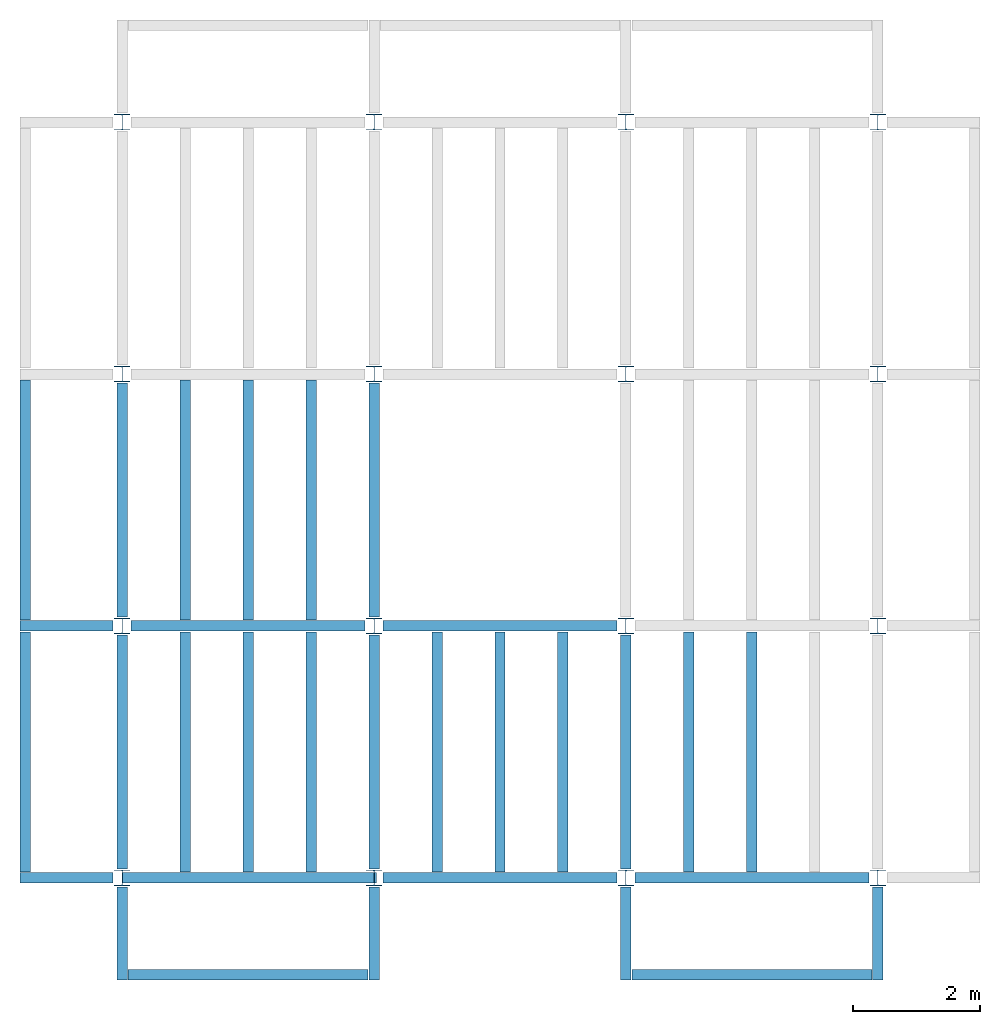
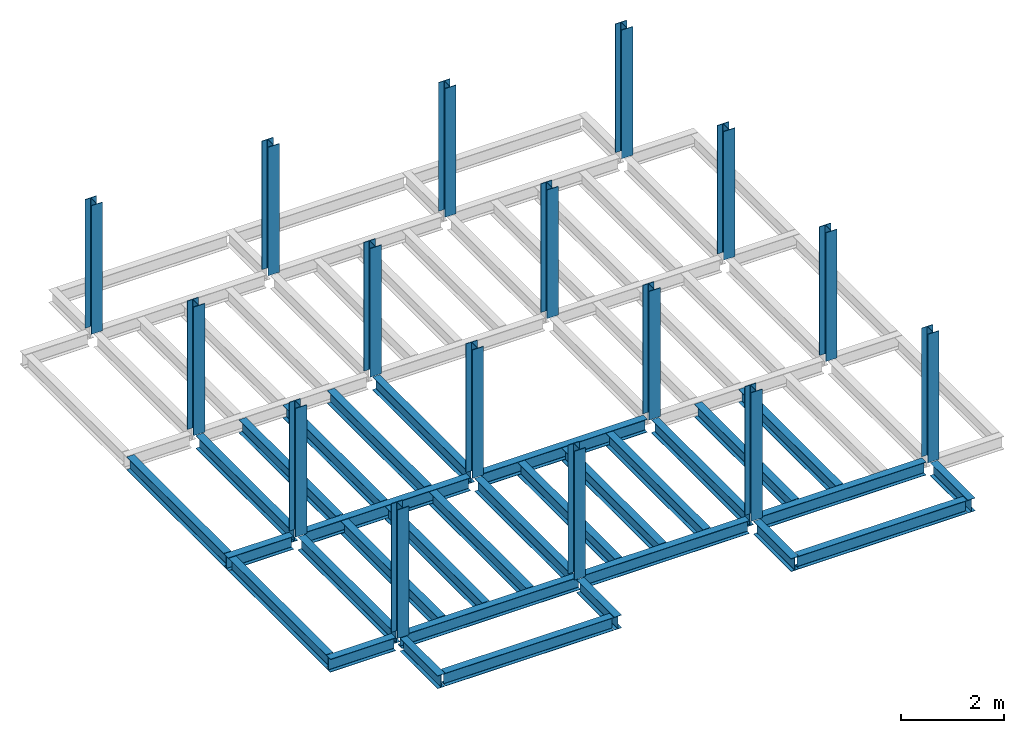
# One storey, part 1 of 3: 31 beams, 16 columns, 4 elements without a shape of their own.
"""IFC4 building model written with IfcOpenShell, lengths in feet."""

from ifc_helpers import new_model, entity, si_unit, converted_unit, derived_unit, direction, frame, origin, origin_2d, place, context, subcontext, project, spatial, line, arc, indexed_curve, i_section, outline, extrude, source, transform, mapped, material, type_object, type_shapes, element, aggregate, save


model = new_model("IFC4")

# Units and contexts
model_context = context("Model", 3, precision=0.0001, world=origin(), true_north=direction((6.123233995736766e-17, 1.0)))
plan_context = context("Plan", 3, precision=0.0001, world=origin(), true_north=direction((6.123233995736766e-17, 1.0)))
body_context = subcontext(model_context, "Body", "Model", "MODEL_VIEW")
ifc_project = project(units=[converted_unit("LENGTHUNIT", "FOOT", entity("IfcLengthMeasure", 0.3048), si_unit("LENGTHUNIT", "METRE"), dimensions=[1, 0, 0, 0, 0, 0, 0]), converted_unit("AREAUNIT", "SQUARE FOOT", entity("IfcAreaMeasure", 0.09290304), si_unit("AREAUNIT", "SQUARE_METRE"), dimensions=[2, 0, 0, 0, 0, 0, 0]), converted_unit("PLANEANGLEUNIT", "DEGREE", entity("IfcPlaneAngleMeasure", 0.017453292519943278), si_unit("PLANEANGLEUNIT", "RADIAN"), dimensions=[0, 0, 0, 0, 0, 0, 0]), converted_unit("VOLUMEUNIT", "CUBIC FOOT", entity("IfcVolumeMeasure", 0.028316846592000004), si_unit("VOLUMEUNIT", "CUBIC_METRE"), dimensions=[3, 0, 0, 0, 0, 0, 0]), si_unit("PRESSUREUNIT", "PASCAL"), derived_unit("MASSDENSITYUNIT", [(si_unit("MASSUNIT", "GRAM", prefix="KILO"), 1), (si_unit("LENGTHUNIT", "METRE"), -3)]), derived_unit("VAPORPERMEABILITYUNIT", [(si_unit("LENGTHUNIT", "METRE"), -1), (si_unit("TIMEUNIT", "SECOND"), 1)]), derived_unit("USERDEFINED", [(si_unit("MASSUNIT", "GRAM", prefix="KILO"), 1), (si_unit("LENGTHUNIT", "METRE"), 3), (si_unit("TIMEUNIT", "SECOND"), -3), (si_unit("ELECTRICCURRENTUNIT", "AMPERE"), -2)]), derived_unit("MODULUSOFELASTICITYUNIT", [(si_unit("MASSUNIT", "GRAM", prefix="KILO"), 1), (si_unit("LENGTHUNIT", "METRE"), -1), (si_unit("TIMEUNIT", "SECOND"), -2)]), derived_unit("THERMALEXPANSIONCOEFFICIENTUNIT", [(si_unit("THERMODYNAMICTEMPERATUREUNIT", "KELVIN"), -1)]), derived_unit("SPECIFICHEATCAPACITYUNIT", [(si_unit("TIMEUNIT", "SECOND"), -2), (si_unit("THERMODYNAMICTEMPERATUREUNIT", "KELVIN"), -1), (si_unit("LENGTHUNIT", "METRE"), 2)]), derived_unit("THERMALCONDUCTANCEUNIT", [(si_unit("MASSUNIT", "GRAM", prefix="KILO"), 1), (si_unit("TIMEUNIT", "SECOND"), -3), (si_unit("THERMODYNAMICTEMPERATUREUNIT", "KELVIN"), -1), (si_unit("LENGTHUNIT", "METRE"), 1)])], contexts=[model_context, plan_context])

# Site, building, storey
site_placement = place(None, origin())
site = spatial("IfcSite", under=ifc_project, at=site_placement, CompositionType="ELEMENT")
building_placement = place(site_placement, origin())
building = spatial("IfcBuilding", under=site, at=building_placement, CompositionType="ELEMENT")
storey_placement = place(building_placement, frame((0.0, 0.0, 99.875)))
storey = spatial("IfcBuildingStorey", under=building, at=storey_placement, Name="STR 11", CompositionType="ELEMENT", Elevation=99.875)

# Columns
ifc_material = material(Name="Steel ASTM A992", Category="Metal")
column_type = type_object("IfcColumnType", Name="W10X49", PredefinedType="COLUMN", material=ifc_material)
shared_shape_1 = source(origin(), body_context, "Body", "SweptSolid", [
    extrude(outline(indexed_curve([(-0.41666666666666663, -0.4166666666666676), (0.41666666666666663, -0.4166666666666676), (0.41666666666666663, -0.3699999999999996), (0.055833333333333846, -0.3699999999999996), (0.02637055078389421, -0.35779611588277277), (0.014166666666666636, -0.32833333333333287), (0.01416666666666665, 0.32833333333333303), (0.026370550783893467, 0.3577961158827727), (0.05583333333333332, 0.3700000000000003), (0.41666666666666663, 0.3700000000000003), (0.41666666666666663, 0.4166666666666656), (-0.41666666666666663, 0.4166666666666656), (-0.41666666666666663, 0.3700000000000003), (-0.05583333333333365, 0.3700000000000003), (-0.02637055078389416, 0.3577961158827734), (-0.014166666666666685, 0.32833333333333387), (-0.014166666666666685, -0.32833333333333264), (-0.026370550783893578, -0.3577961158827721), (-0.055833333333333374, -0.3699999999999996), (-0.41666666666666663, -0.3699999999999996)], segments=[line(1, 2, 3, 4), arc(4, 5, 6), line(6, 7), arc(7, 8, 9), line(9, 10, 11, 12, 13, 14), arc(14, 15, 16), line(16, 17), arc(17, 18, 19), line(19, 20, 1)], self_intersect=False)), frame((0.0, 0.0, 99.875), z_axis=(0.0, 0.0, 1.0), x_axis=(-1.0, 0.0, 0.0)), (0.0, 0.0, 1.0), 10.0),
])
type_shapes(column_type, [shared_shape_1])
for number, where, z_axis, x_axis, name in (
    (1, (0.0, 0.0, -99.875), (0.0, 0.0, 1.0), (-1.0, 0.0, 0.0), "W10X49"),
    (2, (0.0, 13.0, -99.875), (0.0, 0.0, 1.0), (-1.0, 0.0, 0.0), "W10X49"),
    (3, (0.0, 26.0, -99.875), (0.0, 0.0, 1.0), (-1.0, 0.0, 0.0), "W10X49"),
    (4, (0.0, 39.0, -99.875), (0.0, 0.0, 1.0), (-1.0, 0.0, 0.0), "W10X49"),
    (5, (13.0, 0.0, -99.875), (0.0, 0.0, 1.0), (-1.0, 0.0, 0.0), "W10X49"),
    (6, (13.0, 13.0, -99.875), (0.0, 0.0, 1.0), (-1.0, 0.0, 0.0), "W10X49"),
    (7, (13.0, 26.0, -99.875), (0.0, 0.0, 1.0), (-1.0, 0.0, 0.0), "W10X49"),
    (8, (13.0, 39.0, -99.875), (0.0, 0.0, 1.0), (-1.0, 0.0, 0.0), "W10X49"),
    (9, (26.0, 0.0, -99.875), (0.0, 0.0, 1.0), (-1.0, 0.0, 0.0), "W10X49"),
    (10, (26.0, 13.0, -99.875), (0.0, 0.0, 1.0), (-1.0, 0.0, 0.0), "W10X49"),
    (11, (26.0, 26.0, -99.875), (0.0, 0.0, 1.0), (-1.0, 0.0, 0.0), "W10X49"),
    (12, (26.0, 39.0, -99.875), (0.0, 0.0, 1.0), (-1.0, 0.0, 0.0), "W10X49"),
    (13, (39.0, 0.0, -99.875), (0.0, 0.0, 1.0), (-1.0, 0.0, 0.0), "W10X49"),
    (14, (39.0, 13.0, -99.875), (0.0, 0.0, 1.0), (-1.0, 0.0, 0.0), "W10X49"),
    (15, (39.0, 26.0, -99.875), (0.0, 0.0, 1.0), (-1.0, 0.0, 0.0), "W10X49"),
    (16, (39.0, 39.0, -99.875), (0.0, 0.0, 1.0), (-1.0, 0.0, 0.0), "W10X49"),
):
    element("IfcColumn", number, at=place(storey_placement, frame(where, z_axis=z_axis, x_axis=x_axis)), inside=storey, type_object=column_type, material=ifc_material, Name=name, ObjectType="W Shapes-Column:W10X49", PredefinedType="COLUMN", context=body_context, shape_type="MappedRepresentation", body=[
        mapped(shared_shape_1, transform((0.0, 0.0, 0.0), scale=1.0)),
    ])

# Beams
beam_type_1 = type_object("IfcBeamType", Name="W12X26", PredefinedType="JOIST", material=ifc_material)
shared_shape_2 = source(origin(), body_context, "Body", "SweptSolid", [
    extrude(outline(indexed_curve([(-0.27041666666666714, -0.47666666666666574), (-0.27041666666666714, -0.5083333333333351), (0.2704166666666669, -0.5083333333333351), (0.2704166666666669, -0.47666666666666574), (0.03458333333333309, -0.47666666666666574), (0.016905663803669493, -0.46934433619632937), (0.009583333333333202, -0.4516666666666659), (0.0095833333333332, 0.45166666666666705), (0.01690566380366948, 0.4693443361963307), (0.03458333333333325, 0.4766666666666671), (0.2704166666666669, 0.4766666666666671), (0.2704166666666669, 0.5083333333333312), (-0.2704166666666655, 0.5083333333333312), (-0.2704166666666655, 0.4766666666666671), (-0.034583333333333514, 0.47666666666666707), (-0.016905663803669865, 0.46934433619633054), (-0.009583333333333737, 0.45166666666666694), (-0.009583333333333735, -0.4516666666666658), (-0.01690566380367013, -0.4693443361963295), (-0.03458333333333368, -0.47666666666666574)], segments=[line(1, 2, 3, 4, 5), arc(5, 6, 7), line(7, 8), arc(8, 9, 10), line(10, 11, 12, 13, 14, 15), arc(15, 16, 17), line(17, 18), arc(18, 19, 20), line(20, 1)], self_intersect=False)), frame((-6.103346456692914, 0.0, 0.0), z_axis=(-1.0, 0.0, 0.0), x_axis=(0.0, -1.0, 0.0)), (0.0, 0.0, -1.0), 12.083333333333323),
])
type_shapes(beam_type_1, [shared_shape_2])
beam_1_placement = place(storey_placement, frame((6.561679790026266, 13.0, -0.50833333333334)))
element("IfcBeam", 17, at=beam_1_placement, inside=storey, type_object=beam_type_1, material=ifc_material, Name="W12X26", ObjectType="W Shapes:W12X26", PredefinedType="JOIST", context=body_context, shape_type="MappedRepresentation", body=[
    mapped(shared_shape_2, transform((0.0, 0.0, 0.0), scale=1.0)),
])
for number, where, z_axis, x_axis, name in (
    (18, (0.0, 6.561679790026247, -0.50833333333334), (0.0, 0.0, 1.0), (0.0, 1.0, 0.0), "W12X26"),
    (19, (26.0, 6.561679790026162, -0.50833333333334), (0.0, 0.0, 1.0), (0.0, 1.0, 0.0), "W12X26"),
    (20, (13.0, 6.561679790026204, -0.50833333333334), (0.0, 0.0, 1.0), (0.0, 1.0, 0.0), "W12X26"),
):
    element("IfcBeam", number, at=place(storey_placement, frame(where, z_axis=z_axis, x_axis=x_axis)), inside=storey, type_object=beam_type_1, material=ifc_material, Name=name, ObjectType="W Shapes:W12X26", PredefinedType="JOIST", context=body_context, shape_type="MappedRepresentation", body=[
        mapped(shared_shape_2, transform((0.0, 0.0, 0.0), scale=1.0)),
    ])
beam_type_2 = type_object("IfcBeamType", Name="W12X26", PredefinedType="JOIST", material=ifc_material)
shared_shape_3 = source(origin(), body_context, "Body", "SweptSolid", [
    extrude(outline(indexed_curve([(-0.27041666666666714, -0.47666666666666574), (-0.27041666666666714, -0.5083333333333351), (0.2704166666666669, -0.5083333333333351), (0.2704166666666669, -0.47666666666666574), (0.03458333333333309, -0.47666666666666574), (0.016905663803669493, -0.46934433619632937), (0.009583333333333202, -0.4516666666666659), (0.0095833333333332, 0.45166666666666705), (0.01690566380366948, 0.4693443361963307), (0.03458333333333325, 0.4766666666666671), (0.2704166666666669, 0.4766666666666671), (0.2704166666666669, 0.5083333333333312), (-0.2704166666666655, 0.5083333333333312), (-0.2704166666666655, 0.4766666666666671), (-0.034583333333333514, 0.47666666666666707), (-0.016905663803669865, 0.46934433619633054), (-0.009583333333333737, 0.45166666666666694), (-0.009583333333333735, -0.4516666666666658), (-0.01690566380367013, -0.4693443361963295), (-0.03458333333333368, -0.47666666666666574)], segments=[line(1, 2, 3, 4, 5), arc(5, 6, 7), line(7, 8), arc(8, 9, 10), line(10, 11, 12, 13, 14, 15), arc(15, 16, 17), line(17, 18), arc(18, 19, 20), line(20, 1)], self_intersect=False)), frame((-6.226706036745409, 0.0, 0.0), z_axis=(-1.0, 0.0, 0.0), x_axis=(0.0, -1.0, 0.0)), (0.0, 0.0, -1.0), 12.08333333333333),
])
type_shapes(beam_type_2, [shared_shape_3])
for number, where, name in (
    (21, (19.68503937007876, 13.0, -0.50833333333334), "W12X26"),
    (22, (19.68503937007874, 0.0, -0.50833333333334), "W12X26"),
):
    element("IfcBeam", number, at=place(storey_placement, frame(where)), inside=storey, type_object=beam_type_2, material=ifc_material, Name=name, ObjectType="W Shapes:W12X26", PredefinedType="JOIST", context=body_context, shape_type="MappedRepresentation", body=[
        mapped(shared_shape_3, transform((0.0, 0.0, 0.0), scale=1.0)),
    ])
for number, where, z_axis, x_axis, name in (
    (23, (0.0, 19.68503937007874, -0.50833333333334), (0.0, 0.0, 1.0), (0.0, 1.0, 0.0), "W12X26"),
    (24, (13.0, 19.685039370078698, -0.50833333333334), (0.0, 0.0, 1.0), (0.0, 1.0, 0.0), "W12X26"),
):
    element("IfcBeam", number, at=place(storey_placement, frame(where, z_axis=z_axis, x_axis=x_axis)), inside=storey, type_object=beam_type_2, material=ifc_material, Name=name, ObjectType="W Shapes:W12X26", PredefinedType="JOIST", context=body_context, shape_type="MappedRepresentation", body=[
        mapped(shared_shape_3, transform((0.0, 0.0, 0.0), scale=1.0)),
    ])

# Assembly, beams
assembly_1_placement = place(storey_placement, origin())
assembly_1 = element("IfcElementAssembly", 25, at=assembly_1_placement, inside=storey, Name="Structural Framing System", ObjectType="Structural Beam System:Structural Framing System", AssemblyPlace="NOTDEFINED", PredefinedType="BEAM_GRID")
beam_type_3 = type_object("IfcBeamType", Name="W12X26", PredefinedType="JOIST", material=ifc_material)
shared_shape_4 = source(origin(), body_context, "Body", "SweptSolid", [
    extrude(outline(indexed_curve([(-0.27041666666666714, -0.47666666666666574), (-0.27041666666666714, -0.5083333333333351), (0.2704166666666669, -0.5083333333333351), (0.2704166666666669, -0.47666666666666574), (0.03458333333333309, -0.47666666666666574), (0.016905663803669493, -0.46934433619632937), (0.009583333333333202, -0.4516666666666659), (0.0095833333333332, 0.45166666666666705), (0.01690566380366948, 0.4693443361963307), (0.03458333333333325, 0.4766666666666671), (0.2704166666666669, 0.4766666666666671), (0.2704166666666669, 0.5083333333333312), (-0.2704166666666655, 0.5083333333333312), (-0.2704166666666655, 0.4766666666666671), (-0.034583333333333514, 0.47666666666666707), (-0.016905663803669865, 0.46934433619633054), (-0.009583333333333737, 0.45166666666666694), (-0.009583333333333735, -0.4516666666666658), (-0.01690566380367013, -0.4693443361963295), (-0.03458333333333368, -0.47666666666666574)], segments=[line(1, 2, 3, 4, 5), arc(5, 6, 7), line(7, 8), arc(8, 9, 10), line(10, 11, 12, 13, 14, 15), arc(15, 16, 17), line(17, 18), arc(18, 19, 20), line(20, 1)], self_intersect=False)), frame((-6.187916666666566, 0.0, 0.0), z_axis=(-1.0, 0.0, 0.0), x_axis=(0.0, -1.0, 0.0)), (0.0, 0.0, -1.0), 12.375833333333075),
])
type_shapes(beam_type_3, [shared_shape_4])
beam_2_placement = place(assembly_1_placement, frame((3.250000000000031, 6.499999999999844, -0.50833333333334), z_axis=(0.0, 0.0, 1.0), x_axis=(0.0, 1.0, 0.0)))
beam_2 = element("IfcBeam", 26, at=beam_2_placement, type_object=beam_type_3, material=ifc_material, Name="W12X26", ObjectType="W Shapes:W12X26", PredefinedType="JOIST", context=body_context, shape_type="MappedRepresentation", body=[
    mapped(shared_shape_4, transform((0.0, 0.0, 0.0), scale=1.0)),
])
beam_3_placement = place(assembly_1_placement, frame((6.500000000000053, 6.4999999999998455, -0.50833333333334), z_axis=(0.0, 0.0, 1.0), x_axis=(0.0, 1.0, 0.0)))
beam_3 = element("IfcBeam", 27, at=beam_3_placement, type_object=beam_type_3, material=ifc_material, Name="W12X26", ObjectType="W Shapes:W12X26", PredefinedType="JOIST", context=body_context, shape_type="MappedRepresentation", body=[
    mapped(shared_shape_4, transform((0.0, 0.0, 0.0), scale=1.0)),
])
beam_4_placement = place(assembly_1_placement, frame((9.750000000000075, 6.499999999999844, -0.50833333333334), z_axis=(0.0, 0.0, 1.0), x_axis=(0.0, 1.0, 0.0)))
beam_4 = element("IfcBeam", 28, at=beam_4_placement, type_object=beam_type_3, material=ifc_material, Name="W12X26", ObjectType="W Shapes:W12X26", PredefinedType="JOIST", context=body_context, shape_type="MappedRepresentation", body=[
    mapped(shared_shape_4, transform((0.0, 0.0, 0.0), scale=1.0)),
])
aggregate(assembly_1, [beam_2, beam_3, beam_4])

assembly_2_placement = place(storey_placement, origin())
assembly_2 = element("IfcElementAssembly", 29, at=assembly_2_placement, inside=storey, Name="Structural Framing System", ObjectType="Structural Beam System:Structural Framing System", AssemblyPlace="NOTDEFINED", PredefinedType="BEAM_GRID")
beam_5_placement = place(assembly_2_placement, frame((3.2500000000000515, 19.49999999999968, -0.50833333333334), z_axis=(0.0, 0.0, 1.0), x_axis=(0.0, 1.0, 0.0)))
beam_5 = element("IfcBeam", 30, at=beam_5_placement, type_object=beam_type_3, material=ifc_material, Name="W12X26", ObjectType="W Shapes:W12X26", PredefinedType="JOIST", context=body_context, shape_type="MappedRepresentation", body=[
    mapped(shared_shape_4, transform((0.0, 0.0, 0.0), scale=1.0)),
])
beam_6_placement = place(assembly_2_placement, frame((6.500000000000073, 19.499999999999666, -0.50833333333334), z_axis=(0.0, 0.0, 1.0), x_axis=(0.0, 1.0, 0.0)))
beam_6 = element("IfcBeam", 31, at=beam_6_placement, type_object=beam_type_3, material=ifc_material, Name="W12X26", ObjectType="W Shapes:W12X26", PredefinedType="JOIST", context=body_context, shape_type="MappedRepresentation", body=[
    mapped(shared_shape_4, transform((0.0, 0.0, 0.0), scale=1.0)),
])
beam_7_placement = place(assembly_2_placement, frame((9.750000000000094, 19.49999999999966, -0.50833333333334), z_axis=(0.0, 0.0, 1.0), x_axis=(0.0, 1.0, 0.0)))
beam_7 = element("IfcBeam", 32, at=beam_7_placement, type_object=beam_type_3, material=ifc_material, Name="W12X26", ObjectType="W Shapes:W12X26", PredefinedType="JOIST", context=body_context, shape_type="MappedRepresentation", body=[
    mapped(shared_shape_4, transform((0.0, 0.0, 0.0), scale=1.0)),
])
aggregate(assembly_2, [beam_5, beam_6, beam_7])

assembly_3_placement = place(storey_placement, origin())
assembly_3 = element("IfcElementAssembly", 33, at=assembly_3_placement, inside=storey, Name="Structural Framing System", ObjectType="Structural Beam System:Structural Framing System", AssemblyPlace="NOTDEFINED", PredefinedType="BEAM_GRID")
beam_8_placement = place(assembly_3_placement, frame((16.250000000000092, 6.499999999999801, -0.50833333333334), z_axis=(0.0, 0.0, 1.0), x_axis=(0.0, 1.0, 0.0)))
beam_8 = element("IfcBeam", 34, at=beam_8_placement, type_object=beam_type_3, material=ifc_material, Name="W12X26", ObjectType="W Shapes:W12X26", PredefinedType="JOIST", context=body_context, shape_type="MappedRepresentation", body=[
    mapped(shared_shape_4, transform((0.0, 0.0, 0.0), scale=1.0)),
])
beam_9_placement = place(assembly_3_placement, frame((19.5000000000001, 6.499999999999801, -0.50833333333334), z_axis=(0.0, 0.0, 1.0), x_axis=(0.0, 1.0, 0.0)))
beam_9 = element("IfcBeam", 35, at=beam_9_placement, type_object=beam_type_3, material=ifc_material, Name="W12X26", ObjectType="W Shapes:W12X26", PredefinedType="JOIST", context=body_context, shape_type="MappedRepresentation", body=[
    mapped(shared_shape_4, transform((0.0, 0.0, 0.0), scale=1.0)),
])
beam_10_placement = place(assembly_3_placement, frame((22.750000000000107, 6.499999999999801, -0.50833333333334), z_axis=(0.0, 0.0, 1.0), x_axis=(0.0, 1.0, 0.0)))
beam_10 = element("IfcBeam", 36, at=beam_10_placement, type_object=beam_type_3, material=ifc_material, Name="W12X26", ObjectType="W Shapes:W12X26", PredefinedType="JOIST", context=body_context, shape_type="MappedRepresentation", body=[
    mapped(shared_shape_4, transform((0.0, 0.0, 0.0), scale=1.0)),
])
aggregate(assembly_3, [beam_8, beam_9, beam_10])

assembly_4_placement = place(storey_placement, origin())
assembly_4 = element("IfcElementAssembly", 37, at=assembly_4_placement, inside=storey, Name="Structural Framing System", ObjectType="Structural Beam System:Structural Framing System", AssemblyPlace="NOTDEFINED", PredefinedType="BEAM_GRID")
beam_11_placement = place(assembly_4_placement, frame((29.2500000000001, 6.49999999999975, -0.50833333333334), z_axis=(0.0, 0.0, 1.0), x_axis=(0.0, 1.0, 0.0)))
beam_11 = element("IfcBeam", 38, at=beam_11_placement, type_object=beam_type_3, material=ifc_material, Name="W12X26", ObjectType="W Shapes:W12X26", PredefinedType="JOIST", context=body_context, shape_type="MappedRepresentation", body=[
    mapped(shared_shape_4, transform((0.0, 0.0, 0.0), scale=1.0)),
])
beam_12_placement = place(assembly_4_placement, frame((32.5000000000001, 6.499999999999737, -0.50833333333334), z_axis=(0.0, 0.0, 1.0), x_axis=(0.0, 1.0, 0.0)))
beam_12 = element("IfcBeam", 39, at=beam_12_placement, type_object=beam_type_3, material=ifc_material, Name="W12X26", ObjectType="W Shapes:W12X26", PredefinedType="JOIST", context=body_context, shape_type="MappedRepresentation", body=[
    mapped(shared_shape_4, transform((0.0, 0.0, 0.0), scale=1.0)),
])
aggregate(assembly_4, [beam_11, beam_12])

# Beams
for number, where, z_axis, x_axis, name in (
    (40, (-5.0, 6.499999999999858, -0.50833333333334), (0.0, 0.0, 1.0), (0.0, -1.0, 0.0), "W12X26"),
    (41, (-5.0, 19.499999999999705, -0.50833333333334), (0.0, 0.0, 1.0), (0.0, 1.0, 0.0), "W12X26"),
):
    element("IfcBeam", number, at=place(storey_placement, frame(where, z_axis=z_axis, x_axis=x_axis)), inside=storey, type_object=beam_type_3, material=ifc_material, Name=name, ObjectType="W Shapes:W12X26", PredefinedType="JOIST", context=body_context, shape_type="MappedRepresentation", body=[
        mapped(shared_shape_4, transform((0.0, 0.0, 0.0), scale=1.0)),
    ])
beam_type_4 = type_object("IfcBeamType", Name="W12X26", PredefinedType="JOIST", material=ifc_material)
shared_shape_5 = source(origin(), body_context, "Body", "SweptSolid", [
    extrude(outline(indexed_curve([(-0.27041666666666714, -0.47666666666666574), (-0.27041666666666714, -0.5083333333333351), (0.2704166666666669, -0.5083333333333351), (0.2704166666666669, -0.47666666666666574), (0.03458333333333309, -0.47666666666666574), (0.016905663803669493, -0.46934433619632937), (0.009583333333333202, -0.4516666666666659), (0.0095833333333332, 0.45166666666666705), (0.01690566380366948, 0.4693443361963307), (0.03458333333333325, 0.4766666666666671), (0.2704166666666669, 0.4766666666666671), (0.2704166666666669, 0.5083333333333312), (-0.2704166666666655, 0.5083333333333312), (-0.2704166666666655, 0.4766666666666671), (-0.034583333333333514, 0.47666666666666707), (-0.016905663803669865, 0.46934433619633054), (-0.009583333333333737, 0.45166666666666694), (-0.009583333333333735, -0.4516666666666658), (-0.01690566380367013, -0.4693443361963295), (-0.03458333333333368, -0.47666666666666574)], segments=[line(1, 2, 3, 4, 5), arc(5, 6, 7), line(7, 8), arc(8, 9, 10), line(10, 11, 12, 13, 14, 15), arc(15, 16, 17), line(17, 18), arc(18, 19, 20), line(20, 1)], self_intersect=False)), frame((-6.165026246719308, 0.0, 0.0), z_axis=(-1.0, 0.0, 0.0), x_axis=(0.0, -1.0, 0.0)), (0.0, 0.0, -1.0), 12.08333333333334),
])
type_shapes(beam_type_4, [shared_shape_5])
beam_13_placement = place(storey_placement, frame((32.623359580052536, 0.0, -0.50833333333334)))
element("IfcBeam", 42, at=beam_13_placement, inside=storey, type_object=beam_type_4, material=ifc_material, Name="W12X26", ObjectType="W Shapes:W12X26", PredefinedType="JOIST", context=body_context, shape_type="MappedRepresentation", body=[
    mapped(shared_shape_5, transform((0.0, 0.0, 0.0), scale=1.0)),
])
beam_type_5 = type_object("IfcBeamType", Name="W12X26", PredefinedType="JOIST", material=ifc_material)
shared_shape_6 = source(origin(), body_context, "Body", "SweptSolid", [
    extrude(outline(indexed_curve([(0.47666666666666574, -0.2704166666666672), (0.5083333333333351, -0.2704166666666672), (0.5083333333333351, 0.27041666666666686), (0.47666666666666574, 0.27041666666666686), (0.47666666666666574, 0.03458333333333307), (0.46934433619632937, 0.016905663803669473), (0.4516666666666659, 0.00958333333333318), (-0.45166666666666705, 0.00958333333333318), (-0.4693443361963307, 0.01690566380366946), (-0.4766666666666671, 0.03458333333333323), (-0.4766666666666671, 0.27041666666666686), (-0.5083333333333312, 0.27041666666666686), (-0.5083333333333312, -0.27041666666666553), (-0.4766666666666671, -0.27041666666666553), (-0.47666666666666707, -0.034583333333333535), (-0.46934433619633054, -0.016905663803669885), (-0.45166666666666694, -0.00958333333333376), (0.4516666666666658, -0.009583333333333756), (0.4693443361963295, -0.01690566380367015), (0.47666666666666574, -0.0345833333333337)], segments=[line(1, 2, 3, 4, 5), arc(5, 6, 7), line(7, 8), arc(8, 9, 10), line(10, 11, 12, 13, 14, 15), arc(15, 16, 17), line(17, 18), arc(18, 19, 20), line(20, 1)], self_intersect=False)), frame((-2.0416666666666208, 0.0, 0.0), z_axis=(1.0, 0.0, 0.0), x_axis=(0.0, 0.0, -1.0)), (0.0, 0.0, 1.0), 4.812083333333336),
])
type_shapes(beam_type_5, [shared_shape_6])
for number, where, z_axis, x_axis, name in (
    (43, (39.0, -2.50000000000058, -0.50833333333334), (0.0, 0.0, 1.0), (0.0, -1.0, 0.0), "W12X26"),
    (44, (26.0, -2.500000000000538, -0.50833333333334), (0.0, 0.0, 1.0), (0.0, -1.0, 0.0), "W12X26"),
    (45, (-2.499999999999853, 13.0, -0.50833333333334), (0.0, 0.0, 1.0), (-1.0, 0.0, 0.0), "W12X26"),
    (46, (-2.4999999999998743, 0.0, -0.50833333333334), (0.0, 0.0, 1.0), (-1.0, 0.0, 0.0), "W12X26"),
):
    element("IfcBeam", number, at=place(storey_placement, frame(where, z_axis=z_axis, x_axis=x_axis)), inside=storey, type_object=beam_type_5, material=ifc_material, Name=name, ObjectType="W Shapes:W12X26", PredefinedType="JOIST", context=body_context, shape_type="MappedRepresentation", body=[
        mapped(shared_shape_6, transform((0.0, 0.0, 0.0), scale=1.0)),
    ])
beam_type_6 = type_object("IfcBeamType", Name="W12X26", PredefinedType="JOIST", material=ifc_material)
shared_shape_7 = source(origin(), body_context, "Body", "SweptSolid", [
    extrude(outline(indexed_curve([(0.47666666666666574, -0.2704166666666672), (0.5083333333333351, -0.2704166666666672), (0.5083333333333351, 0.27041666666666686), (0.47666666666666574, 0.27041666666666686), (0.47666666666666574, 0.03458333333333307), (0.46934433619632937, 0.016905663803669473), (0.4516666666666659, 0.00958333333333318), (-0.45166666666666705, 0.00958333333333318), (-0.4693443361963307, 0.01690566380366946), (-0.4766666666666671, 0.03458333333333323), (-0.4766666666666671, 0.27041666666666686), (-0.5083333333333312, 0.27041666666666686), (-0.5083333333333312, -0.27041666666666553), (-0.4766666666666671, -0.27041666666666553), (-0.47666666666666707, -0.034583333333333535), (-0.46934433619633054, -0.016905663803669885), (-0.45166666666666694, -0.00958333333333376), (0.4516666666666658, -0.009583333333333756), (0.4693443361963295, -0.01690566380367015), (0.47666666666666574, -0.0345833333333337)], segments=[line(1, 2, 3, 4, 5), arc(5, 6, 7), line(7, 8), arc(8, 9, 10), line(10, 11, 12, 13, 14, 15), arc(15, 16, 17), line(17, 18), arc(18, 19, 20), line(20, 1)], self_intersect=False)), frame((-6.187916666666685, 0.0, 0.0), z_axis=(1.0, 0.0, 0.0), x_axis=(0.0, 0.0, -1.0)), (0.0, 0.0, 1.0), 12.375833333333318),
])
type_shapes(beam_type_6, [shared_shape_7])
beam_14_placement = place(storey_placement, frame((32.50000000000002, -5.0, -0.50833333333334)))
element("IfcBeam", 47, at=beam_14_placement, inside=storey, type_object=beam_type_6, material=ifc_material, Name="W Shapes:W12X26", ObjectType="W Shapes:W12X26", PredefinedType="JOIST", context=body_context, shape_type="MappedRepresentation", body=[
    mapped(shared_shape_7, transform((0.0, 0.0, 0.0), scale=1.0)),
])
beam_type_7 = type_object("IfcBeamType", Name="W12X26", PredefinedType="JOIST", material=ifc_material)
shared_shape_8 = source(origin(), body_context, "Body", "SweptSolid", [
    extrude(outline(indexed_curve([(-0.2704166666666641, -0.50833333333334), (0.27041666666666764, -0.50833333333334), (0.27041666666666764, -0.4766666666666737), (0.03458333333333563, -0.4766666666666879), (0.01690566380367109, -0.4693443361963432), (0.009583333333335275, -0.4516666666666822), (0.009583333333335275, 0.4516666666666538), (0.01690566380367109, 0.46934433619631477), (0.03458333333333563, 0.47666666666665947), (0.2704166666666694, 0.47666666666665947), (0.27041666666666764, 0.5083333333333258), (-0.27041666666666586, 0.5083333333333258), (-0.27041666666666586, 0.47666666666665947), (-0.03458333333333208, 0.47666666666665947), (-0.016905663803667537, 0.46934433619631477), (-0.009583333333331723, 0.4516666666666538), (-0.009583333333331723, -0.4516666666666822), (-0.016905663803667537, -0.4693443361963432), (-0.03458333333333208, -0.4766666666666737), (-0.27041666666666586, -0.4766666666666737)], segments=[line(1, 2, 3, 4), arc(4, 5, 6), line(6, 7), arc(7, 8, 9), line(9, 10, 11, 12, 13, 14), arc(14, 15, 16), line(16, 17), arc(17, 18, 19), line(19, 20, 1)], self_intersect=False)), frame((13.0, -0.45833333333387627, 99.36666666666663), z_axis=(0.0, -1.0, 0.0), x_axis=(-1.0, 0.0, 0.0)), (0.0, 0.0, 1.0), 4.812083333333337),
])
type_shapes(beam_type_7, [shared_shape_8])
beam_15_placement = place(storey_placement, frame((0.0, 0.0, -99.875)))
element("IfcBeam", 48, at=beam_15_placement, inside=storey, type_object=beam_type_7, material=ifc_material, Name="W12X26", ObjectType="W Shapes:W12X26", PredefinedType="JOIST", context=body_context, shape_type="MappedRepresentation", body=[
    mapped(shared_shape_8, transform((0.0, 0.0, 0.0), scale=1.0)),
])
beam_type_8 = type_object("IfcBeamType", Name="W12X26", PredefinedType="JOIST", material=ifc_material)
shared_shape_9 = source(origin(), body_context, "Body", "SweptSolid", [
    extrude(outline(indexed_curve([(-0.5083333333333258, -0.270416666666665), (-0.47666666666665947, -0.270416666666665), (-0.4766666666666737, -0.034583333333333854), (-0.469344336196329, -0.016905663803669313), (-0.451666666666668, -0.009583333333333499), (0.451666666666668, -0.009583333333333499), (0.469344336196329, -0.016905663803669313), (0.4766666666666737, -0.034583333333332966), (0.4766666666666737, -0.27041666666666675), (0.50833333333334, -0.27041666666666675), (0.50833333333334, 0.27041666666666675), (0.4766666666666737, 0.27041666666666764), (0.4766666666666737, 0.034583333333333854), (0.469344336196329, 0.016905663803669313), (0.451666666666668, 0.009583333333333499), (-0.451666666666668, 0.009583333333333499), (-0.469344336196329, 0.016905663803669313), (-0.47666666666665947, 0.034583333333332966), (-0.47666666666665947, 0.27041666666666675), (-0.5083333333333258, 0.27041666666666764)], segments=[line(1, 2, 3), arc(3, 4, 5), line(5, 6), arc(6, 7, 8), line(8, 9, 10, 11, 12, 13), arc(13, 14, 15), line(15, 16), arc(16, 17, 18), line(18, 19, 20, 1)], self_intersect=False)), frame((0.3120833333333186, -5.0, 99.36666666666665), z_axis=(1.0, 0.0, 0.0), x_axis=(0.0, 0.0, -1.0)), (0.0, 0.0, 1.0), 12.37583333333332),
])
type_shapes(beam_type_8, [shared_shape_9])
beam_16_placement = place(storey_placement, frame((0.0, 0.0, -99.875)))
element("IfcBeam", 49, at=beam_16_placement, inside=storey, type_object=beam_type_8, material=ifc_material, Name="W Shapes:W12X26", ObjectType="W Shapes:W12X26", PredefinedType="JOIST", context=body_context, shape_type="MappedRepresentation", body=[
    mapped(shared_shape_9, transform((0.0, 0.0, 0.0), scale=1.0)),
])
beam_type_9 = type_object("IfcBeamType", Name="W12X26", PredefinedType="JOIST", material=ifc_material)
shared_shape_10 = source(origin(), body_context, "Body", "SweptSolid", [
    extrude(outline(indexed_curve([(-0.27041666666666686, -0.50833333333334), (0.27041666666666553, -0.50833333333334), (0.27041666666666553, -0.4766666666666737), (0.03458333333333355, -0.4766666666666879), (0.016905663803669275, -0.4693443361963432), (0.009583333333333723, -0.4516666666666822), (0.009583333333333218, 0.4516666666666538), (0.01690566380366942, 0.46934433619631477), (0.034583333333333716, 0.47666666666665947), (0.2704166666666672, 0.47666666666665947), (0.2704166666666672, 0.5083333333333258), (-0.27041666666666686, 0.5083333333333258), (-0.27041666666666686, 0.47666666666665947), (-0.03458333333333308, 0.47666666666665947), (-0.01690566380366875, 0.46934433619631477), (-0.009583333333333164, 0.4516666666666538), (-0.009583333333332694, -0.4516666666666822), (-0.01690566380366881, -0.4693443361963432), (-0.03458333333333319, -0.4766666666666737), (-0.27041666666666686, -0.4766666666666737)], segments=[line(1, 2, 3, 4), arc(4, 5, 6), line(6, 7), arc(7, 8, 9), line(9, 10, 11, 12, 13, 14), arc(14, 15, 16), line(16, 17), arc(17, 18, 19), line(19, 20, 1)], self_intersect=False)), frame((0.0, -0.45833333333383364, 99.36666666666663), z_axis=(0.0, -1.0, 0.0), x_axis=(-1.0, 0.0, 0.0)), (0.0, 0.0, 1.0), 4.812083333333337),
])
type_shapes(beam_type_9, [shared_shape_10])
beam_17_placement = place(storey_placement, frame((0.0, 0.0, -99.875)))
element("IfcBeam", 50, at=beam_17_placement, inside=storey, type_object=beam_type_9, material=ifc_material, Name="W12X26", ObjectType="W Shapes:W12X26", PredefinedType="JOIST", context=body_context, shape_type="MappedRepresentation", body=[
    mapped(shared_shape_10, transform((0.0, 0.0, 0.0), scale=1.0)),
])
beam_type_10 = type_object("IfcBeamType", Name="W12X26", PredefinedType="BEAM")
beam_18_placement = place(storey_placement, frame((0.0, 0.0, -0.50833333333334), z_axis=(-1.0, 0.0, 0.0), x_axis=(0.0, -1.0, 0.0)))
element("IfcBeam", 51, at=beam_18_placement, inside=storey, type_object=beam_type_10, material=ifc_material, Name="W12X26", ObjectType="W12X26", context=model_context, shape_type="SweptSolid", body=[
    extrude(i_section(OverallWidth=0.5408333333333333, OverallDepth=1.0166666666666666, WebThickness=0.019166666666666665, FlangeThickness=0.03166666666666666, FilletRadius=0.024999999999999998, at=origin_2d()), origin(), (0.0, 0.0, -1.0), 13.123359580052494),
])

save(model, "model.ifc")
